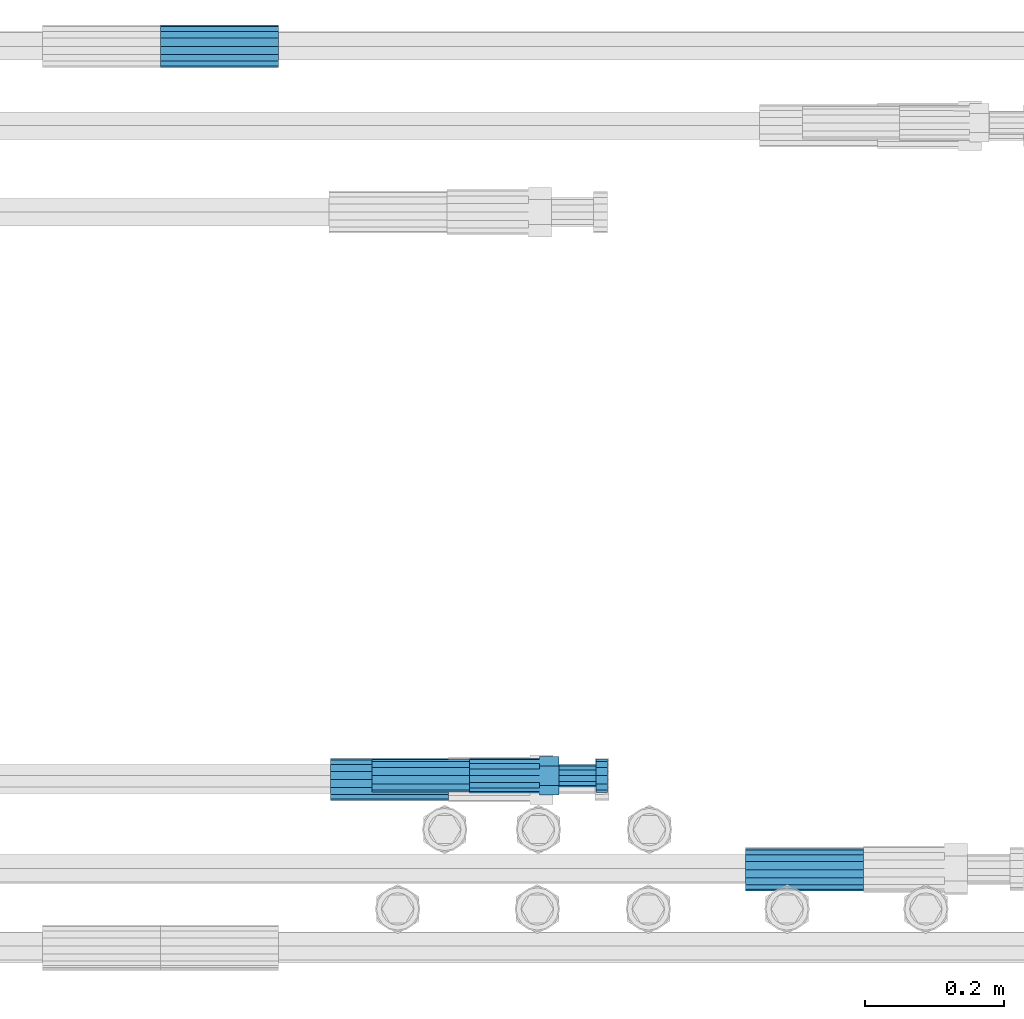
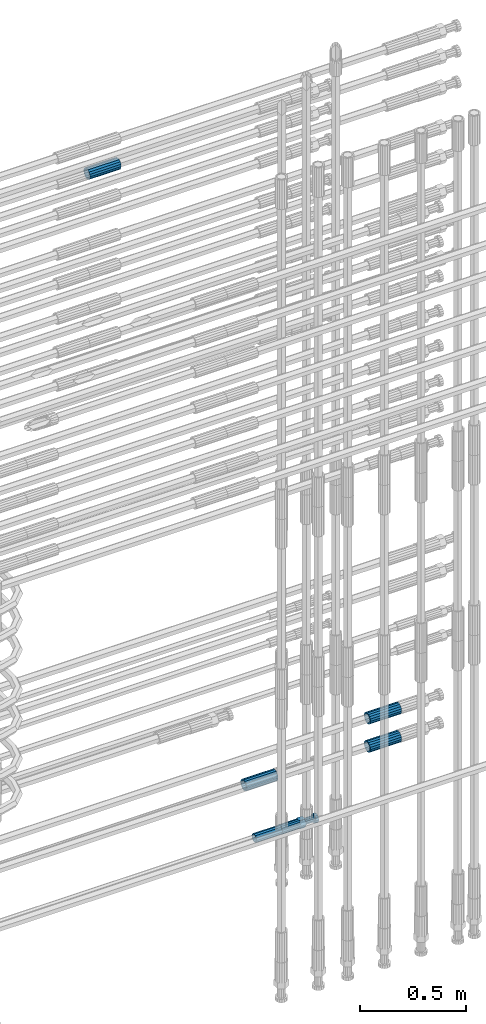
# One storey, part 85 of 119: 6 beams.
"""IFC2X3 building model written with IfcOpenShell, lengths in millimetres."""

from ifc_helpers import new_model, si_unit, frame, origin_with_axes, place, context, subcontext, project, spatial, faceted_brep, material, type_object, element, save


model = new_model("IFC2X3")

# Units and contexts
model_context = context("Model", 3, precision=1e-05, world=origin_with_axes())
body_context = subcontext(model_context, "Body", "Model", "MODEL_VIEW")
ifc_project = project(units=[si_unit("LENGTHUNIT", "METRE", prefix="MILLI"), si_unit("AREAUNIT", "SQUARE_METRE"), si_unit("VOLUMEUNIT", "CUBIC_METRE"), si_unit("MASSUNIT", "GRAM", prefix="KILO"), si_unit("TIMEUNIT", "SECOND"), si_unit("PLANEANGLEUNIT", "RADIAN"), si_unit("SOLIDANGLEUNIT", "STERADIAN"), si_unit("THERMODYNAMICTEMPERATUREUNIT", "DEGREE_CELSIUS"), si_unit("LUMINOUSINTENSITYUNIT", "LUMEN")], contexts=[model_context])

# Site, building, storey
site_placement = place(None, origin_with_axes())
site = spatial("IfcSite", under=ifc_project, at=site_placement, CompositionType="ELEMENT")
building_placement = place(site_placement, origin_with_axes())
building = spatial("IfcBuilding", under=site, at=building_placement, Name="Undefined", CompositionType="ELEMENT")
storey_placement = place(building_placement, origin_with_axes())
storey = spatial("IfcBuildingStorey", under=building, at=storey_placement, Name="Undefined", CompositionType="ELEMENT", Elevation=0.0)

# Beams
ifc_material = material(Name="STEEL/S275")
beam_type_1 = type_object("IfcBeamType", PredefinedType="NOTDEFINED")
beam_1_placement = place(storey_placement, frame((2038568.98023304, 6205213.38994599, 19336.3894197672), z_axis=(0.0, 0.0, 1.0), x_axis=(1.0, 0.0, 0.0)))
element("IfcBeam", 1, at=beam_1_placement, inside=storey, type_object=beam_type_1, material=ifc_material, Name="AG40N", context=body_context, shape_type="Brep", body=[
    faceted_brep([(1.62981450557709e-09, -23.4999999990687, 0.0), (7.45058059692383e-09, -21.7111690142192, 8.99306066057534), (170.000002125278, -21.711168999318, 8.99306066022245), (170.000002127141, -23.4999999844003, -3.66071617463604e-10), (4.65661287307739e-09, -16.6170093587134, 16.6170093578889), (170.000002122484, -16.6170093440451, 16.6170093575288), (1.86264514923096e-09, -8.99306066217832, 21.7111690140277), (170.000002118759, -8.99306064750999, 21.7111690136603), (2.3283064365387e-10, 9.31322574615479e-10, 23.5), (170.000002114102, 1.28056854009628e-08, 23.4999999996485), (-6.51925802230835e-09, 8.99306065868586, 21.7111690140241), (170.00000211224, 8.99306067335419, 21.7111690136639), (-7.45058059692383e-09, 16.6170093561523, 16.6170093578853), (170.000002109446, 16.6170093708206, 16.6170093575324), (-9.31322574615479e-09, 21.711169013055, 8.99306066057534), (170.000002108514, 21.7111690277234, 8.99306066022245), (-1.16415321826935e-09, 23.5000000009313, 0.0), (170.000002108514, 23.5000000144355, -3.66071617463604e-10), (-8.38190317153931e-09, 21.7111690151505, -8.99306066059444), (170.000002110377, 21.7111690300517, -8.9930606609546), (-5.58793544769287e-09, 16.6170093598776, -16.6170093579008), (170.000002113171, 16.6170093745459, -16.6170093582609), (-9.31322574615479e-10, 8.99306066334248, -21.7111690140396), (170.000002115965, 8.99306067801081, -21.7111690143961), (2.3283064365387e-10, 9.31322574615479e-10, -23.5), (170.00000211969, 1.7927959561348e-08, -23.5000000003843), (5.58793544769287e-09, -8.99306065752171, -21.7111690140396), (170.000002123415, -8.99306064285338, -21.7111690143961), (8.38190317153931e-09, -16.6170093549881, -16.6170093579008), (170.000002125278, -16.6170093403198, -16.6170093582646), (9.31322574615479e-09, -21.7111690121237, -8.99306066059444), (170.000002127141, -21.7111689972226, -8.9930606609546), (1.11758708953857e-08, -30.4999999990687, -9.54969436861575e-12), (1.30385160446167e-08, -28.1783257392235, -11.6718446871514), (170.000002129003, -28.1783257243223, -11.6718446875116), (170.000002129935, -30.4999999841675, -3.66071617463604e-10), (1.02445483207703e-08, -21.5667568228673, -21.5667568262129), (170.000002128072, -21.566756808199, -21.5667568265694), (7.45058059692383e-09, -11.6718446831219, -28.1783257416196), (170.000002125278, -11.6718446684536, -28.1783257419834), (3.72529029846191e-09, 3.95812094211578e-09, -30.5000000000277), (170.00000211969, 1.83936208486557e-08, -30.5000000003879), (-9.31322574615479e-10, 11.6718446905725, -28.1783257416232), (170.000002115965, 11.6718447052408, -28.1783257419797), (-6.51925802230835e-09, 21.5667568286881, -21.5667568262093), (170.000002110377, 21.5667568433564, -21.5667568265694), (-9.31322574615479e-09, 28.178325742716, -11.6718446871478), (170.000002108514, 28.1783257573843, -11.6718446875079), (-1.21071934700012e-08, 30.5, -5.91171556152403e-12), (170.000002106652, 30.5000000144355, -3.62433638656512e-10), (-1.21071934700012e-08, 28.1783257401548, 11.6718446871359), (170.00000210572, 28.1783257548232, 11.6718446867794), (-1.02445483207703e-08, 21.5667568240315, 21.5667568261974), (170.000002107583, 21.566756838467, 21.5667568258409), (-7.45058059692383e-09, 11.671844684286, 28.1783257416041), (170.000002110377, 11.6718446989544, 28.178325741244), (-2.79396772384644e-09, -2.56113708019257e-09, 30.5000000000159), (170.000002114102, 1.18743628263474e-08, 30.4999999996558), (1.86264514923096e-09, -11.6718446896411, 28.1783257416114), (170.000002118759, -11.67184467474, 28.178325741244), (7.45058059692383e-09, -21.5667568275239, 21.5667568261974), (170.000002123415, -21.5667568126228, 21.5667568258373), (1.02445483207703e-08, -28.1783257415518, 11.6718446871359), (170.000002127141, -28.1783257271163, 11.6718446867794)], [[[0, 1, 2, 3]], [[1, 4, 5, 2]], [[4, 6, 7, 5]], [[6, 8, 9, 7]], [[8, 10, 11, 9]], [[10, 12, 13, 11]], [[12, 14, 15, 13]], [[14, 16, 17, 15]], [[16, 18, 19, 17]], [[18, 20, 21, 19]], [[20, 22, 23, 21]], [[22, 24, 25, 23]], [[24, 26, 27, 25]], [[26, 28, 29, 27]], [[28, 30, 31, 29]], [[30, 0, 3, 31]], [[32, 33, 34, 35]], [[33, 36, 37, 34]], [[36, 38, 39, 37]], [[38, 40, 41, 39]], [[40, 42, 43, 41]], [[42, 44, 45, 43]], [[44, 46, 47, 45]], [[46, 48, 49, 47]], [[48, 50, 51, 49]], [[50, 52, 53, 51]], [[52, 54, 55, 53]], [[54, 56, 57, 55]], [[56, 58, 59, 57]], [[58, 60, 61, 59]], [[60, 62, 63, 61]], [[62, 32, 35, 63]], [[37, 39, 41, 43, 45, 47, 49, 51, 53, 55, 57, 59, 61, 63, 35, 34], [5, 7, 9, 11, 13, 15, 17, 19, 21, 23, 25, 27, 29, 31, 3, 2]], [[62, 60, 58, 56, 54, 52, 50, 48, 46, 44, 42, 40, 38, 36, 33, 32], [30, 28, 26, 24, 22, 20, 18, 16, 14, 12, 10, 8, 6, 4, 1, 0]]]),
])
beam_2_placement = place(storey_placement, frame((2038568.98023304, 6205212.98994599, 19499.2694197672), z_axis=(0.0, 0.0, 1.0), x_axis=(1.0, 0.0, 0.0)))
element("IfcBeam", 2, at=beam_2_placement, inside=storey, type_object=beam_type_1, material=ifc_material, Name="AG40N", context=body_context, shape_type="Brep", body=[
    faceted_brep([(1.62981450557709e-09, -23.4999999990687, 0.0), (7.45058059692383e-09, -21.7111690142192, 8.99306066057534), (170.000002125278, -21.711168999318, 8.99306066022245), (170.000002127141, -23.4999999844003, -3.66071617463604e-10), (4.65661287307739e-09, -16.6170093587134, 16.6170093578889), (170.000002122484, -16.6170093440451, 16.6170093575288), (1.86264514923096e-09, -8.99306066217832, 21.7111690140277), (170.000002118759, -8.99306064750999, 21.7111690136603), (2.3283064365387e-10, 9.31322574615479e-10, 23.5), (170.000002114102, 1.28056854009628e-08, 23.4999999996485), (-6.51925802230835e-09, 8.99306065868586, 21.7111690140241), (170.00000211224, 8.99306067335419, 21.7111690136639), (-7.45058059692383e-09, 16.6170093561523, 16.6170093578853), (170.000002109446, 16.6170093708206, 16.6170093575324), (-9.31322574615479e-09, 21.711169013055, 8.99306066057534), (170.000002108514, 21.7111690277234, 8.99306066022245), (-1.16415321826935e-09, 23.5000000009313, 0.0), (170.000002108514, 23.5000000144355, -3.66071617463604e-10), (-8.38190317153931e-09, 21.7111690151505, -8.99306066059444), (170.000002110377, 21.7111690300517, -8.9930606609546), (-5.58793544769287e-09, 16.6170093598776, -16.6170093579008), (170.000002113171, 16.6170093745459, -16.6170093582609), (-9.31322574615479e-10, 8.99306066334248, -21.7111690140396), (170.000002115965, 8.99306067801081, -21.7111690143961), (2.3283064365387e-10, 9.31322574615479e-10, -23.5), (170.00000211969, 1.7927959561348e-08, -23.5000000003843), (5.58793544769287e-09, -8.99306065752171, -21.7111690140396), (170.000002123415, -8.99306064285338, -21.7111690143961), (8.38190317153931e-09, -16.6170093549881, -16.6170093579008), (170.000002125278, -16.6170093403198, -16.6170093582646), (9.31322574615479e-09, -21.7111690121237, -8.99306066059444), (170.000002127141, -21.7111689972226, -8.9930606609546), (1.11758708953857e-08, -30.4999999990687, -9.54969436861575e-12), (1.30385160446167e-08, -28.1783257392235, -11.6718446871514), (170.000002129003, -28.1783257243223, -11.6718446875116), (170.000002129935, -30.4999999841675, -3.66071617463604e-10), (1.02445483207703e-08, -21.5667568228673, -21.5667568262129), (170.000002128072, -21.566756808199, -21.5667568265694), (7.45058059692383e-09, -11.6718446831219, -28.1783257416196), (170.000002125278, -11.6718446684536, -28.1783257419834), (3.72529029846191e-09, 3.95812094211578e-09, -30.5000000000277), (170.00000211969, 1.83936208486557e-08, -30.5000000003879), (-9.31322574615479e-10, 11.6718446905725, -28.1783257416232), (170.000002115965, 11.6718447052408, -28.1783257419797), (-6.51925802230835e-09, 21.5667568286881, -21.5667568262093), (170.000002110377, 21.5667568433564, -21.5667568265694), (-9.31322574615479e-09, 28.178325742716, -11.6718446871478), (170.000002108514, 28.1783257573843, -11.6718446875079), (-1.21071934700012e-08, 30.5, -5.91171556152403e-12), (170.000002106652, 30.5000000144355, -3.62433638656512e-10), (-1.21071934700012e-08, 28.1783257401548, 11.6718446871359), (170.00000210572, 28.1783257548232, 11.6718446867794), (-1.02445483207703e-08, 21.5667568240315, 21.5667568261974), (170.000002107583, 21.566756838467, 21.5667568258409), (-7.45058059692383e-09, 11.671844684286, 28.1783257416041), (170.000002110377, 11.6718446989544, 28.178325741244), (-2.79396772384644e-09, -2.56113708019257e-09, 30.5000000000159), (170.000002114102, 1.18743628263474e-08, 30.4999999996558), (1.86264514923096e-09, -11.6718446896411, 28.1783257416114), (170.000002118759, -11.67184467474, 28.178325741244), (7.45058059692383e-09, -21.5667568275239, 21.5667568261974), (170.000002123415, -21.5667568126228, 21.5667568258373), (1.02445483207703e-08, -28.1783257415518, 11.6718446871359), (170.000002127141, -28.1783257271163, 11.6718446867794)], [[[0, 1, 2, 3]], [[1, 4, 5, 2]], [[4, 6, 7, 5]], [[6, 8, 9, 7]], [[8, 10, 11, 9]], [[10, 12, 13, 11]], [[12, 14, 15, 13]], [[14, 16, 17, 15]], [[16, 18, 19, 17]], [[18, 20, 21, 19]], [[20, 22, 23, 21]], [[22, 24, 25, 23]], [[24, 26, 27, 25]], [[26, 28, 29, 27]], [[28, 30, 31, 29]], [[30, 0, 3, 31]], [[32, 33, 34, 35]], [[33, 36, 37, 34]], [[36, 38, 39, 37]], [[38, 40, 41, 39]], [[40, 42, 43, 41]], [[42, 44, 45, 43]], [[44, 46, 47, 45]], [[46, 48, 49, 47]], [[48, 50, 51, 49]], [[50, 52, 53, 51]], [[52, 54, 55, 53]], [[54, 56, 57, 55]], [[56, 58, 59, 57]], [[58, 60, 61, 59]], [[60, 62, 63, 61]], [[62, 32, 35, 63]], [[37, 39, 41, 43, 45, 47, 49, 51, 53, 55, 57, 59, 61, 63, 35, 34], [5, 7, 9, 11, 13, 15, 17, 19, 21, 23, 25, 27, 29, 31, 3, 2]], [[62, 60, 58, 56, 54, 52, 50, 48, 46, 44, 42, 40, 38, 36, 33, 32], [30, 28, 26, 24, 22, 20, 18, 16, 14, 12, 10, 8, 6, 4, 1, 0]]]),
])
beam_3_placement = place(storey_placement, frame((2037971.04023304, 6205343.08994599, 19244.4894217954), z_axis=(0.0, 0.0, 1.0), x_axis=(1.0, 0.0, 0.0)))
element("IfcBeam", 3, at=beam_3_placement, inside=storey, type_object=beam_type_1, material=ifc_material, Name="AG40N", context=body_context, shape_type="Brep", body=[
    faceted_brep([(1.62981450557709e-09, -23.4999999990687, 0.0), (7.45058059692383e-09, -21.7111690142192, 8.99306066057534), (170.000002125278, -21.711168999318, 8.99306066022245), (170.000002127141, -23.4999999844003, -3.66071617463604e-10), (4.65661287307739e-09, -16.6170093587134, 16.6170093578889), (170.000002122484, -16.6170093440451, 16.6170093575288), (1.86264514923096e-09, -8.99306066217832, 21.7111690140277), (170.000002118759, -8.99306064750999, 21.7111690136603), (2.3283064365387e-10, 9.31322574615479e-10, 23.5), (170.000002114102, 1.28056854009628e-08, 23.4999999996485), (-6.51925802230835e-09, 8.99306065868586, 21.7111690140241), (170.00000211224, 8.99306067335419, 21.7111690136639), (-7.45058059692383e-09, 16.6170093561523, 16.6170093578853), (170.000002109446, 16.6170093708206, 16.6170093575324), (-9.31322574615479e-09, 21.711169013055, 8.99306066057534), (170.000002108514, 21.7111690277234, 8.99306066022245), (-1.16415321826935e-09, 23.5000000009313, 0.0), (170.000002108514, 23.5000000144355, -3.66071617463604e-10), (-8.38190317153931e-09, 21.7111690151505, -8.99306066059444), (170.000002110377, 21.7111690300517, -8.9930606609546), (-5.58793544769287e-09, 16.6170093598776, -16.6170093579008), (170.000002113171, 16.6170093745459, -16.6170093582609), (-9.31322574615479e-10, 8.99306066334248, -21.7111690140396), (170.000002115965, 8.99306067801081, -21.7111690143961), (2.3283064365387e-10, 9.31322574615479e-10, -23.5), (170.00000211969, 1.7927959561348e-08, -23.5000000003843), (5.58793544769287e-09, -8.99306065752171, -21.7111690140396), (170.000002123415, -8.99306064285338, -21.7111690143961), (8.38190317153931e-09, -16.6170093549881, -16.6170093579008), (170.000002125278, -16.6170093403198, -16.6170093582646), (9.31322574615479e-09, -21.7111690121237, -8.99306066059444), (170.000002127141, -21.7111689972226, -8.9930606609546), (1.11758708953857e-08, -30.4999999990687, -9.54969436861575e-12), (1.30385160446167e-08, -28.1783257392235, -11.6718446871514), (170.000002129003, -28.1783257243223, -11.6718446875116), (170.000002129935, -30.4999999841675, -3.66071617463604e-10), (1.02445483207703e-08, -21.5667568228673, -21.5667568262129), (170.000002128072, -21.566756808199, -21.5667568265694), (7.45058059692383e-09, -11.6718446831219, -28.1783257416196), (170.000002125278, -11.6718446684536, -28.1783257419834), (3.72529029846191e-09, 3.95812094211578e-09, -30.5000000000277), (170.00000211969, 1.83936208486557e-08, -30.5000000003879), (-9.31322574615479e-10, 11.6718446905725, -28.1783257416232), (170.000002115965, 11.6718447052408, -28.1783257419797), (-6.51925802230835e-09, 21.5667568286881, -21.5667568262093), (170.000002110377, 21.5667568433564, -21.5667568265694), (-9.31322574615479e-09, 28.178325742716, -11.6718446871478), (170.000002108514, 28.1783257573843, -11.6718446875079), (-1.21071934700012e-08, 30.5, -5.91171556152403e-12), (170.000002106652, 30.5000000144355, -3.62433638656512e-10), (-1.21071934700012e-08, 28.1783257401548, 11.6718446871359), (170.00000210572, 28.1783257548232, 11.6718446867794), (-1.02445483207703e-08, 21.5667568240315, 21.5667568261974), (170.000002107583, 21.566756838467, 21.5667568258409), (-7.45058059692383e-09, 11.671844684286, 28.1783257416041), (170.000002110377, 11.6718446989544, 28.178325741244), (-2.79396772384644e-09, -2.56113708019257e-09, 30.5000000000159), (170.000002114102, 1.18743628263474e-08, 30.4999999996558), (1.86264514923096e-09, -11.6718446896411, 28.1783257416114), (170.000002118759, -11.67184467474, 28.178325741244), (7.45058059692383e-09, -21.5667568275239, 21.5667568261974), (170.000002123415, -21.5667568126228, 21.5667568258373), (1.02445483207703e-08, -28.1783257415518, 11.6718446871359), (170.000002127141, -28.1783257271163, 11.6718446867794)], [[[0, 1, 2, 3]], [[1, 4, 5, 2]], [[4, 6, 7, 5]], [[6, 8, 9, 7]], [[8, 10, 11, 9]], [[10, 12, 13, 11]], [[12, 14, 15, 13]], [[14, 16, 17, 15]], [[16, 18, 19, 17]], [[18, 20, 21, 19]], [[20, 22, 23, 21]], [[22, 24, 25, 23]], [[24, 26, 27, 25]], [[26, 28, 29, 27]], [[28, 30, 31, 29]], [[30, 0, 3, 31]], [[32, 33, 34, 35]], [[33, 36, 37, 34]], [[36, 38, 39, 37]], [[38, 40, 41, 39]], [[40, 42, 43, 41]], [[42, 44, 45, 43]], [[44, 46, 47, 45]], [[46, 48, 49, 47]], [[48, 50, 51, 49]], [[50, 52, 53, 51]], [[52, 54, 55, 53]], [[54, 56, 57, 55]], [[56, 58, 59, 57]], [[58, 60, 61, 59]], [[60, 62, 63, 61]], [[62, 32, 35, 63]], [[37, 39, 41, 43, 45, 47, 49, 51, 53, 55, 57, 59, 61, 63, 35, 34], [5, 7, 9, 11, 13, 15, 17, 19, 21, 23, 25, 27, 29, 31, 3, 2]], [[62, 60, 58, 56, 54, 52, 50, 48, 46, 44, 42, 40, 38, 36, 33, 32], [30, 28, 26, 24, 22, 20, 18, 16, 14, 12, 10, 8, 6, 4, 1, 0]]]),
])
beam_4_placement = place(storey_placement, frame((2037895.91007889, 6206399.98994599, 22212.9893152167), z_axis=(0.0, 0.0, 1.0), x_axis=(-0.99999999999998, 1.98000110685822e-07, 0.0)))
element("IfcBeam", 4, at=beam_4_placement, inside=storey, type_object=beam_type_1, material=ifc_material, Name="AG40N", context=body_context, shape_type="Brep", body=[
    faceted_brep([(1.62981450557709e-09, -23.4999999990687, 0.0), (7.45058059692383e-09, -21.7111690142192, 8.99306066057534), (170.000002125278, -21.711168999318, 8.99306066022245), (170.000002127141, -23.4999999844003, -3.66071617463604e-10), (4.65661287307739e-09, -16.6170093587134, 16.6170093578889), (170.000002122484, -16.6170093440451, 16.6170093575288), (1.86264514923096e-09, -8.99306066217832, 21.7111690140277), (170.000002118759, -8.99306064750999, 21.7111690136603), (2.3283064365387e-10, 9.31322574615479e-10, 23.5), (170.000002114102, 1.28056854009628e-08, 23.4999999996485), (-6.51925802230835e-09, 8.99306065868586, 21.7111690140241), (170.00000211224, 8.99306067335419, 21.7111690136639), (-7.45058059692383e-09, 16.6170093561523, 16.6170093578853), (170.000002109446, 16.6170093708206, 16.6170093575324), (-9.31322574615479e-09, 21.711169013055, 8.99306066057534), (170.000002108514, 21.7111690277234, 8.99306066022245), (-1.16415321826935e-09, 23.5000000009313, 0.0), (170.000002108514, 23.5000000144355, -3.66071617463604e-10), (-8.38190317153931e-09, 21.7111690151505, -8.99306066059444), (170.000002110377, 21.7111690300517, -8.9930606609546), (-5.58793544769287e-09, 16.6170093598776, -16.6170093579008), (170.000002113171, 16.6170093745459, -16.6170093582609), (-9.31322574615479e-10, 8.99306066334248, -21.7111690140396), (170.000002115965, 8.99306067801081, -21.7111690143961), (2.3283064365387e-10, 9.31322574615479e-10, -23.5), (170.00000211969, 1.7927959561348e-08, -23.5000000003843), (5.58793544769287e-09, -8.99306065752171, -21.7111690140396), (170.000002123415, -8.99306064285338, -21.7111690143961), (8.38190317153931e-09, -16.6170093549881, -16.6170093579008), (170.000002125278, -16.6170093403198, -16.6170093582646), (9.31322574615479e-09, -21.7111690121237, -8.99306066059444), (170.000002127141, -21.7111689972226, -8.9930606609546), (1.11758708953857e-08, -30.4999999990687, -9.54969436861575e-12), (1.30385160446167e-08, -28.1783257392235, -11.6718446871514), (170.000002129003, -28.1783257243223, -11.6718446875116), (170.000002129935, -30.4999999841675, -3.66071617463604e-10), (1.02445483207703e-08, -21.5667568228673, -21.5667568262129), (170.000002128072, -21.566756808199, -21.5667568265694), (7.45058059692383e-09, -11.6718446831219, -28.1783257416196), (170.000002125278, -11.6718446684536, -28.1783257419834), (3.72529029846191e-09, 3.95812094211578e-09, -30.5000000000277), (170.00000211969, 1.83936208486557e-08, -30.5000000003879), (-9.31322574615479e-10, 11.6718446905725, -28.1783257416232), (170.000002115965, 11.6718447052408, -28.1783257419797), (-6.51925802230835e-09, 21.5667568286881, -21.5667568262093), (170.000002110377, 21.5667568433564, -21.5667568265694), (-9.31322574615479e-09, 28.178325742716, -11.6718446871478), (170.000002108514, 28.1783257573843, -11.6718446875079), (-1.21071934700012e-08, 30.5, -5.91171556152403e-12), (170.000002106652, 30.5000000144355, -3.62433638656512e-10), (-1.21071934700012e-08, 28.1783257401548, 11.6718446871359), (170.00000210572, 28.1783257548232, 11.6718446867794), (-1.02445483207703e-08, 21.5667568240315, 21.5667568261974), (170.000002107583, 21.566756838467, 21.5667568258409), (-7.45058059692383e-09, 11.671844684286, 28.1783257416041), (170.000002110377, 11.6718446989544, 28.178325741244), (-2.79396772384644e-09, -2.56113708019257e-09, 30.5000000000159), (170.000002114102, 1.18743628263474e-08, 30.4999999996558), (1.86264514923096e-09, -11.6718446896411, 28.1783257416114), (170.000002118759, -11.67184467474, 28.178325741244), (7.45058059692383e-09, -21.5667568275239, 21.5667568261974), (170.000002123415, -21.5667568126228, 21.5667568258373), (1.02445483207703e-08, -28.1783257415518, 11.6718446871359), (170.000002127141, -28.1783257271163, 11.6718446867794)], [[[0, 1, 2, 3]], [[1, 4, 5, 2]], [[4, 6, 7, 5]], [[6, 8, 9, 7]], [[8, 10, 11, 9]], [[10, 12, 13, 11]], [[12, 14, 15, 13]], [[14, 16, 17, 15]], [[16, 18, 19, 17]], [[18, 20, 21, 19]], [[20, 22, 23, 21]], [[22, 24, 25, 23]], [[24, 26, 27, 25]], [[26, 28, 29, 27]], [[28, 30, 31, 29]], [[30, 0, 3, 31]], [[32, 33, 34, 35]], [[33, 36, 37, 34]], [[36, 38, 39, 37]], [[38, 40, 41, 39]], [[40, 42, 43, 41]], [[42, 44, 45, 43]], [[44, 46, 47, 45]], [[46, 48, 49, 47]], [[48, 50, 51, 49]], [[50, 52, 53, 51]], [[52, 54, 55, 53]], [[54, 56, 57, 55]], [[56, 58, 59, 57]], [[58, 60, 61, 59]], [[60, 62, 63, 61]], [[62, 32, 35, 63]], [[37, 39, 41, 43, 45, 47, 49, 51, 53, 55, 57, 59, 61, 63, 35, 34], [5, 7, 9, 11, 13, 15, 17, 19, 21, 23, 25, 27, 29, 31, 3, 2]], [[62, 60, 58, 56, 54, 52, 50, 48, 46, 44, 42, 40, 38, 36, 33, 32], [30, 28, 26, 24, 22, 20, 18, 16, 14, 12, 10, 8, 6, 4, 1, 0]]]),
])
beam_type_2 = type_object("IfcBeamType", PredefinedType="NOTDEFINED")
beam_5_placement = place(storey_placement, frame((2038031.00023304, 6205348.58994599, 18914.989424824), z_axis=(0.0, 0.0, 1.0), x_axis=(1.0, 0.0, 0.0)))
element("IfcBeam", 5, at=beam_5_placement, inside=storey, type_object=beam_type_2, material=ifc_material, Name="AG32N", context=body_context, shape_type="Brep", body=[
    faceted_brep([(1.39698386192322e-09, -18.4999999990687, 0.0), (1.16415321826935e-09, -16.0214699693024, 9.25), (140.000000001164, -16.0214699935168, 9.25), (140.000000001397, -18.5000000232831, 0.0), (6.98491930961609e-10, -9.24999999906868, 16.0214699700118), (140.000000000698, -9.25000002328306, 16.0214699700118), (2.3283064365387e-10, 9.31322574615479e-10, 18.5), (140.000000000233, -2.3283064365387e-08, 18.5), (-2.3283064365387e-10, 9.25000000093132, 16.0214699700118), (139.999999999767, 9.24999997671694, 16.0214699700118), (-6.98491930961609e-10, 16.0214699711651, 9.25), (139.999999999302, 16.0214699469507, 9.25), (-9.31322574615479e-10, 18.5000000009313, 0.0), (139.999999999069, 18.4999999767169, 0.0), (-6.98491930961609e-10, 16.0214699711651, -9.25), (139.999999999302, 16.0214699469507, -9.25), (-2.3283064365387e-10, 9.25000000093132, -16.0214699700118), (139.999999999767, 9.24999997671694, -16.0214699700118), (2.3283064365387e-10, 9.31322574615479e-10, -18.5), (140.000000000233, -2.3283064365387e-08, -18.5), (6.98491930961609e-10, -9.24999999906868, -16.0214699700118), (140.000000000698, -9.25000002328306, -16.0214699700118), (1.16415321826935e-09, -16.0214699693024, -9.25), (140.000000001164, -16.0214699935168, -9.25), (1.62981450557709e-09, -23.4999999990687, 0.0), (1.39698386192322e-09, -20.3515969878063, -11.75), (140.000000001397, -20.3515970120206, -11.75), (140.00000000163, -23.5000000232831, 0.0), (9.31322574615479e-10, -11.7499999990687, -20.351596988934), (140.000000000931, -11.7500000232831, -20.351596988934), (2.3283064365387e-10, 9.31322574615479e-10, -23.5), (140.000000000233, -2.3283064365387e-08, -23.5), (-4.65661287307739e-10, 11.7500000009313, -20.351596988934), (139.999999999534, 11.7499999767169, -20.351596988934), (-9.31322574615479e-10, 20.3515969896689, -11.75), (139.999999999069, 20.3515969654545, -11.75), (-1.16415321826935e-09, 23.5000000009313, 0.0), (139.999999998836, 23.4999999767169, 0.0), (-9.31322574615479e-10, 20.3515969896689, 11.75), (139.999999999069, 20.3515969654545, 11.75), (-4.65661287307739e-10, 11.7500000009313, 20.351596988934), (139.999999999534, 11.7499999767169, 20.351596988934), (2.3283064365387e-10, 9.31322574615479e-10, 23.5), (140.000000000233, -2.3283064365387e-08, 23.5), (9.31322574615479e-10, -11.7499999990687, 20.351596988934), (140.000000000931, -11.7500000232831, 20.351596988934), (1.39698386192322e-09, -20.3515969878063, 11.75), (140.000000001397, -20.3515970120206, 11.75)], [[[0, 1, 2, 3]], [[1, 4, 5, 2]], [[4, 6, 7, 5]], [[6, 8, 9, 7]], [[8, 10, 11, 9]], [[10, 12, 13, 11]], [[12, 14, 15, 13]], [[14, 16, 17, 15]], [[16, 18, 19, 17]], [[18, 20, 21, 19]], [[20, 22, 23, 21]], [[22, 0, 3, 23]], [[24, 25, 26, 27]], [[25, 28, 29, 26]], [[28, 30, 31, 29]], [[30, 32, 33, 31]], [[32, 34, 35, 33]], [[34, 36, 37, 35]], [[36, 38, 39, 37]], [[38, 40, 41, 39]], [[40, 42, 43, 41]], [[42, 44, 45, 43]], [[44, 46, 47, 45]], [[46, 24, 27, 47]], [[29, 31, 33, 35, 37, 39, 41, 43, 45, 47, 27, 26], [5, 7, 9, 11, 13, 15, 17, 19, 21, 23, 3, 2]], [[46, 44, 42, 40, 38, 36, 34, 32, 30, 28, 25, 24], [22, 20, 18, 16, 14, 12, 10, 8, 6, 4, 1, 0]]]),
])
beam_type_3 = type_object("IfcBeamType", Name="ROD50", PredefinedType="NOTDEFINED")
beam_6_placement = place(storey_placement, frame((2038171.00023304, 6205348.58994599, 18914.9894276017), z_axis=(0.0, 0.0, 1.0), x_axis=(1.0, 0.0, 0.0)))
element("IfcBeam", 6, at=beam_6_placement, inside=storey, type_object=beam_type_3, material=ifc_material, Name="AGB32", ObjectType="ROD50", context=body_context, shape_type="Brep", body=[
    faceted_brep([(100.999999995111, 13.8425000002608, 23.9759132212093), (100.999999996508, 17.5285119004548, 17.5915533324223), (100.999999997672, 9.56708580907434, 23.0969883129546), (100.999999995111, 5.14843190740794, 23.9759132212093), (100.999999995111, -13.8425000002608, 23.9759132212093), (129.099999995669, -13.8425000002608, 23.9759132182917), (129.099999995669, 13.8425000002608, 23.9759132182917), (100.999999995111, -5.14843190740794, 23.9759132212093), (100.999999996508, -17.5285119004548, 17.5915533324223), (100.999999997672, -9.56708580907434, 23.0969883129546), (101.000000000233, -27.6849999995902, -8.25639290269464e-08), (129.100000000792, -27.6849999995902, -8.5481588030234e-08), (100.999999998836, -23.5887256683782, 7.09495518143376), (101.00000000163, -23.5887256180868, -7.09495543353478), (101.000000000233, -25.0, 1.70985003933311e-10), (101.000000005355, -13.8425000002608, -23.9759133863372), (129.100000005914, -13.8425000002608, -23.9759133892549), (101.000000003958, -17.5285119721666, -17.5915533734478), (101.000000005355, -5.14843107573688, -23.9759133863372), (101.000000002561, -9.56708580907434, -23.0969883126127), (101.000000005355, 13.8425000002608, -23.9759133863372), (129.100000005914, 13.8425000002608, -23.9759133892549), (101.000000005355, 5.14843107573688, -23.9759133863372), (101.000000002561, 9.56708580907434, -23.0969883126127), (101.000000003958, 17.5285119721666, -17.5915533734478), (101.000000000233, 27.6849999995902, -8.25639290269464e-08), (129.100000000792, 27.6849999995902, -8.5481588030234e-08), (101.00000000163, 23.5887256180868, -7.09495543353478), (101.000000000233, 25.0, 1.70985003933311e-10), (100.999999998836, 23.5887256683782, 7.09495518143376), (-6.98491930961609e-10, -23.0969883129001, 9.56708580912891), (-1.62981450557709e-09, -17.6776695298031, 17.6776695296649), (-2.3283064365387e-09, -9.56708580907434, 23.0969883127837), (-2.56113708019257e-09, 0.0, 25.0), (-2.3283064365387e-09, 9.56708580907434, 23.0969883127837), (-1.62981450557709e-09, 17.6776695298031, 17.6776695296649), (-6.98491930961609e-10, 23.0969883129001, 9.56708580912891), (2.3283064365387e-10, 25.0, 0.0), (1.16415321826935e-09, 23.0969883129001, -9.56708580912891), (2.09547579288483e-09, 17.6776695298031, -17.6776695296649), (2.56113708019257e-09, 9.56708580907434, -23.0969883127837), (2.79396772384644e-09, 0.0, -25.0), (2.56113708019257e-09, -9.56708580907434, -23.0969883127837), (2.09547579288483e-09, -17.6776695298031, -17.6776695296649), (1.16415321826935e-09, -23.0969883129001, -9.56708580912891), (2.3283064365387e-10, -25.0, 0.0), (100.999999999302, 23.0969883129001, 9.5670858092999), (101.000000001164, 23.0969883129001, -9.56708580895793), (101.000000002794, 0.0, -24.999999999829), (101.000000001164, -23.0969883129001, -9.56708580895793), (100.999999999302, -23.0969883129001, 9.5670858092999), (100.999999997439, 0.0, 25.000000000171), (129.49999999837, -14.2894191620871, 8.24999989414209), (129.499999996973, -8.25, 14.2894190565821), (129.49999999674, 0.0, 16.4999998941421), (129.499999996973, 8.25, 14.2894190565821), (129.49999999837, 14.2894191620871, 8.24999989414209), (129.500000000233, 16.5, -1.05857907328755e-07), (129.500000002095, 14.2894191620871, -8.25000010585791), (129.50000000326, 8.25, -14.2894192683016), (129.500000003492, 0.0, -16.5000001058615), (129.50000000326, -8.25, -14.2894192683016), (129.500000002095, -14.2894191620871, -8.25000010586155), (129.500000000233, -16.5, -1.05857907328755e-07), (182.499999996973, 8.25, 14.2894190510815), (182.49999999674, 0.0, 16.4999998886415), (182.49999999837, 14.2894191620871, 8.24999988864147), (182.500000000233, 16.5, -1.11358531285077e-07), (182.500000002095, 14.2894191620871, -8.25000011135853), (182.50000000326, 8.25, -14.2894192738022), (182.500000003492, 0.0, -16.5000001113622), (182.50000000326, -8.25, -14.2894192738022), (182.500000002095, -14.2894191620871, -8.25000011136217), (182.500000000233, -16.5, -1.11358531285077e-07), (182.49999999837, -14.2894191620871, 8.24999988864147), (182.499999996973, -8.25, 14.2894190510815), (182.500000002561, -20.7846096912399, -12.0000001491826), (182.500000004657, -12.0, -20.7846098400078), (199.000000004657, -12.0, -20.7846098417212), (199.000000002561, -20.7846096912399, -12.0000001508961), (182.500000005355, 0.0, -24.0000001491826), (199.000000005355, 0.0, -24.0000001508961), (182.500000004657, 12.0, -20.7846098400078), (199.000000004657, 12.0, -20.7846098417212), (182.500000002561, 20.7846096912399, -12.000000149179), (199.000000002561, 20.7846096912399, -12.0000001508924), (182.500000000233, 24.0, -1.49178958963603e-07), (199.000000000233, 24.0, -1.50892446981743e-07), (182.499999997672, 20.7846096912399, 11.999999850821), (198.999999997672, 20.7846096912399, 11.9999998491076), (182.499999995809, 12.0, 20.7846095416462), (198.999999995809, 12.0, 20.7846095399327), (182.499999995111, 0.0, 23.999999850821), (198.999999995111, 0.0, 23.9999998491076), (182.499999995809, -12.0, 20.7846095416462), (198.999999995809, -12.0, 20.7846095399327), (182.499999997672, -20.7846096912399, 11.999999850821), (198.999999997672, -20.7846096912399, 11.9999998491039), (182.500000000233, -24.0, -1.49178958963603e-07), (199.000000000233, -24.0, -1.50892446981743e-07)], [[[0, 1, 2, 3]], [[4, 5, 6, 0, 3, 7]], [[8, 4, 7, 9]], [[10, 11, 5, 4, 8, 12]], [[13, 10, 12, 14]], [[15, 16, 11, 10, 13, 17]], [[18, 15, 17, 19]], [[20, 21, 16, 15, 18, 22]], [[20, 22, 23, 24]], [[25, 26, 21, 20, 24, 27]], [[25, 27, 28, 29]], [[30, 31, 32, 33, 34, 35, 36, 37, 38, 39, 40, 41, 42, 43, 44, 45]], [[28, 37, 36, 46, 29]], [[27, 47, 38, 37, 28]], [[24, 47, 27]], [[39, 38, 47, 24]], [[23, 40, 39, 24]], [[22, 48, 41, 40, 23]], [[18, 48, 22]], [[19, 42, 41, 48, 18]], [[17, 43, 42, 19]], [[44, 43, 17, 49]], [[13, 49, 17]], [[14, 45, 44, 49, 13]], [[12, 50, 30, 45, 14]], [[8, 50, 12]], [[31, 30, 50, 8]], [[9, 32, 31, 8]], [[7, 51, 33, 32, 9]], [[3, 51, 7]], [[2, 34, 33, 51, 3]], [[1, 35, 34, 2]], [[36, 35, 1, 46]], [[29, 46, 1]], [[0, 6, 26, 25, 29, 1]], [[5, 11, 16, 21, 26, 6]], [[52, 53, 54, 55, 56, 57, 58, 59, 60, 61, 62, 63]], [[64, 55, 54, 65]], [[66, 56, 55, 64]], [[67, 57, 56, 66]], [[68, 58, 57, 67]], [[69, 59, 58, 68]], [[70, 60, 59, 69]], [[71, 61, 60, 70]], [[72, 62, 61, 71]], [[73, 63, 62, 72]], [[74, 52, 63, 73]], [[75, 53, 52, 74]], [[65, 54, 53, 75]], [[76, 77, 78, 79]], [[77, 80, 81, 78]], [[80, 82, 83, 81]], [[82, 84, 85, 83]], [[84, 86, 87, 85]], [[86, 88, 89, 87]], [[88, 90, 91, 89]], [[90, 92, 93, 91]], [[92, 94, 95, 93]], [[94, 96, 97, 95]], [[96, 98, 99, 97]], [[78, 81, 83, 85, 87, 89, 91, 93, 95, 97, 99, 79]], [[98, 76, 79, 99]], [[96, 94, 92, 90, 88, 86, 84, 82, 80, 77, 76, 98], [74, 73, 72, 71, 70, 69, 68, 67, 66, 64, 65, 75]]]),
])

save(model, "model.ifc")
